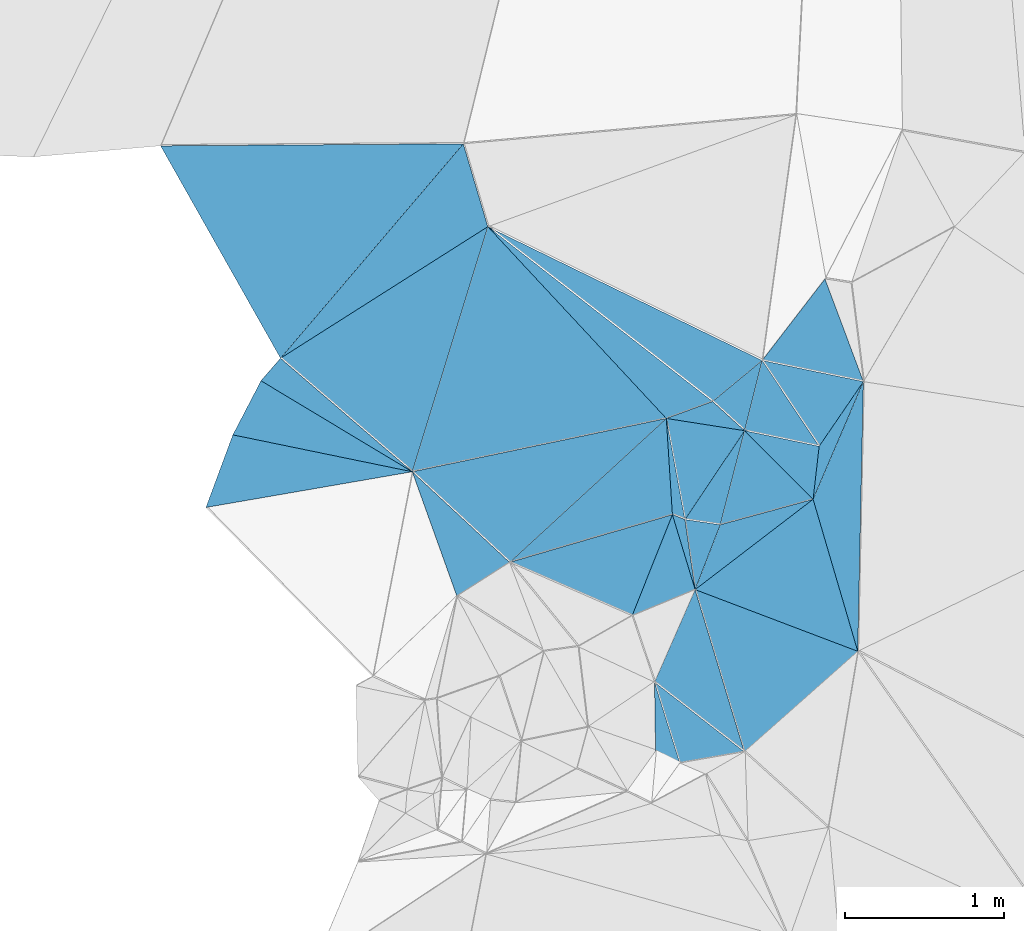
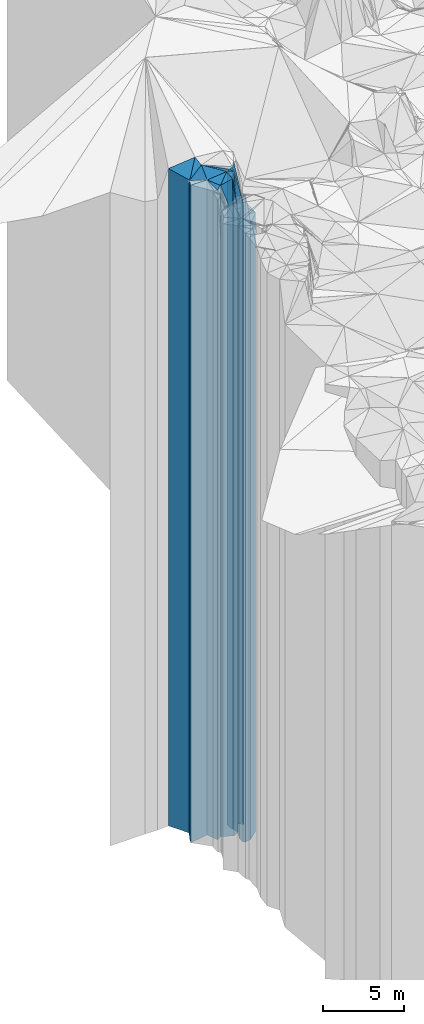
# One storey, part 238 of 275: 34 plates.
"""IFC2X3 building model written with IfcOpenShell, lengths in millimetres."""

from ifc_helpers import new_model, si_unit, frame, origin_with_axes, place, context, subcontext, project, spatial, faceted_brep, material, type_object, element, save


model = new_model("IFC2X3")

# Units and contexts
model_context = context("Model", 3, precision=1e-05, world=origin_with_axes())
body_context = subcontext(model_context, "Body", "Model", "MODEL_VIEW")
ifc_project = project(units=[si_unit("LENGTHUNIT", "METRE", prefix="MILLI"), si_unit("AREAUNIT", "SQUARE_METRE"), si_unit("VOLUMEUNIT", "CUBIC_METRE"), si_unit("MASSUNIT", "GRAM", prefix="KILO"), si_unit("TIMEUNIT", "SECOND"), si_unit("PLANEANGLEUNIT", "RADIAN"), si_unit("SOLIDANGLEUNIT", "STERADIAN"), si_unit("THERMODYNAMICTEMPERATUREUNIT", "DEGREE_CELSIUS"), si_unit("LUMINOUSINTENSITYUNIT", "LUMEN")], contexts=[model_context])

# Site, building, storey
site_placement = place(None, origin_with_axes())
site = spatial("IfcSite", under=ifc_project, at=site_placement, CompositionType="ELEMENT")
building_placement = place(site_placement, origin_with_axes())
building = spatial("IfcBuilding", under=site, at=building_placement, Name="Undefined", CompositionType="ELEMENT")
storey_placement = place(building_placement, origin_with_axes())
storey = spatial("IfcBuildingStorey", under=building, at=storey_placement, Name="Undefined", CompositionType="ELEMENT", Elevation=0.0)

# Plates
ifc_material = material()
plate_type_1 = type_object("IfcPlateType", PredefinedType="NOTDEFINED")
plate_1_placement = place(storey_placement, frame((-137889.922620238, 93996.6602586746, 32554.0), z_axis=(-0.201534010067387, -0.979481517327488, 0.0), x_axis=(-0.979481517327489, 0.201534010067382, 0.0)))
element("IfcPlate", 1, at=plate_1_placement, inside=storey, type_object=plate_type_1, material=ifc_material, Name="00", context=body_context, shape_type="Brep", body=[
    faceted_brep([(2.91038304567337e-11, -24726.0, 0.0), (1228.06140136722, -24926.0, 482.353698730476), (1228.06140136722, 24726.0, 482.353698730476), (2.91038304567337e-11, 24726.0, 0.0), (1154.33959960943, -24896.0, -1.62981450557709e-09), (1154.33959960943, 24726.0, -1.62981450557709e-09)], [[[0, 1, 2, 3]], [[1, 4, 5, 2]], [[4, 0, 3, 5]], [[5, 3, 2]], [[4, 1, 0]]]),
])
plate_type_2 = type_object("IfcPlateType", PredefinedType="NOTDEFINED")
plate_2_placement = place(storey_placement, frame((-135797.607146299, 92232.0594659979, 31079.0), z_axis=(-0.663004384163275, 0.748615513184356, 0.0), x_axis=(0.74861551318436, 0.663004384163271, 0.0)))
element("IfcPlate", 2, at=plate_2_placement, inside=storey, type_object=plate_type_2, material=ifc_material, Name="00", context=body_context, shape_type="Brep", body=[
    faceted_brep([(7.27595761418343e-12, -23251.0, 2.91038304567337e-11), (445.716400146506, -23401.0, 970.482788085908), (445.716400146506, 23251.0, 970.482788085908), (0.0, 23251.0, 2.91038304567337e-11), (955.09161376956, -23451.0, 1.17288436740637e-08), (955.09161376956, 23251.0, 1.17288436740637e-08)], [[[0, 1, 2, 3]], [[1, 4, 5, 2]], [[4, 0, 3, 5]], [[5, 3, 2]], [[4, 1, 0]]]),
])
plate_type_3 = type_object("IfcPlateType", PredefinedType="NOTDEFINED")
plate_3_placement = place(storey_placement, frame((-136107.371292026, 93254.0898833643, 31154.0), z_axis=(0.354732567030753, 0.93496781008106, 0.0), x_axis=(0.934967810081061, -0.354732567030751, 0.0)))
element("IfcPlate", 3, at=plate_3_placement, inside=storey, type_object=plate_type_3, material=ifc_material, Name="00", context=body_context, shape_type="Brep", body=[
    faceted_brep([(0.0, -23326.0, -7.27595761418343e-12), (493.048461914033, -23386.0, 795.866333007813), (493.048461914033, 23326.0, 795.866333007813), (0.0, 23326.0, -7.27595761418343e-12), (1096.03833007813, -23376.0, -1.30967237055302e-10), (1096.03833007813, 23326.0, -1.30967237055302e-10)], [[[0, 1, 2, 3]], [[1, 4, 5, 2]], [[4, 0, 3, 5]], [[5, 3, 2]], [[4, 1, 0]]]),
])
plate_type_4 = type_object("IfcPlateType", PredefinedType="NOTDEFINED")
plate_4_placement = place(storey_placement, frame((-135795.781477125, 94255.6445684663, 31199.0), z_axis=(0.830293936976665, -0.55732573798434, 0.0), x_axis=(-0.557325737984339, -0.830293936976666, 0.0)))
element("IfcPlate", 4, at=plate_4_placement, inside=storey, type_object=plate_type_4, material=ifc_material, Name="00", context=body_context, shape_type="Brep", body=[
    faceted_brep([(1.04591890703887e-11, -25831.0, 0.0), (577.602416992198, -23371.0, 202.917343139648), (577.602416992198, 23371.0, 202.917343139648), (1.04591890703887e-11, 23371.0, 0.0), (674.166137695323, -25701.0, 6.11180439591408e-09), (674.166137695323, 23371.0, 6.11180439591408e-09)], [[[0, 1, 2, 3]], [[1, 4, 5, 2]], [[4, 0, 3, 5]], [[5, 3, 2]], [[4, 1, 0]]]),
])
plate_type_5 = type_object("IfcPlateType", PredefinedType="NOTDEFINED")
plate_5_placement = place(storey_placement, frame((-136250.65043334, 93726.4997558948, 32364.0), z_axis=(0.360757109901238, 0.932659802744659, 0.0), x_axis=(0.932659802744688, -0.360757109901163, 0.0)))
element("IfcPlate", 5, at=plate_5_placement, inside=storey, type_object=plate_type_5, material=ifc_material, Name="00", context=body_context, shape_type="Brep", body=[
    faceted_brep([(1.45519152283669e-11, -24586.0, 1.45519152283669e-11), (-254.558441162109, -24796.0, 551.543273925796), (-254.558441162109, 24536.0, 551.543273925796), (0.0, 24536.0, 7.27595761418343e-12), (84.8528137207322, -24536.0, -6.54836185276508e-11), (84.8528137207322, 24536.0, -6.54836185276508e-11)], [[[0, 1, 2, 3]], [[1, 4, 5, 2]], [[4, 0, 3, 5]], [[5, 3, 2]], [[4, 1, 0]]]),
])
plate_type_6 = type_object("IfcPlateType", PredefinedType="NOTDEFINED")
plate_6_placement = place(storey_placement, frame((-136250.65043334, 93726.4997558948, 32389.0), z_axis=(-0.997995437407364, -0.0632859140258246, 0.0), x_axis=(-0.0632859140258196, 0.997995437407364, 0.0)))
element("IfcPlate", 6, at=plate_6_placement, inside=storey, type_object=plate_type_6, material=ifc_material, Name="00", context=body_context, shape_type="Brep", body=[
    faceted_brep([(0.0, -24561.0, 0.0), (-235.079650878892, -24621.0, 1043.04248046872), (-235.079650878892, 24561.0, 1043.04248046872), (0.0, 24561.0, 0.0), (607.453674316392, -24771.0, 1.42608769237995e-09), (607.453674316392, 24561.0, 1.42608769237995e-09)], [[[0, 1, 2, 3]], [[1, 4, 5, 2]], [[4, 0, 3, 5]], [[5, 3, 2]], [[4, 1, 0]]]),
])
plate_type_7 = type_object("IfcPlateType", PredefinedType="NOTDEFINED")
plate_7_placement = place(storey_placement, frame((-137609.148746292, 93213.2918704249, 32359.0), z_axis=(-0.538762878316238, 0.842457453494479, 0.0), x_axis=(0.842457453494479, 0.538762878316238, 0.0)))
element("IfcPlate", 7, at=plate_7_placement, inside=storey, type_object=plate_type_7, material=ifc_material, Name="00", context=body_context, shape_type="Brep", body=[
    faceted_brep([(0.0, -24531.0, -2.91038304567337e-11), (185.509765624978, -24921.0, 811.22509765625), (185.509765624978, 24531.0, 811.22509765625), (0.0, 24531.0, -2.91038304567337e-11), (394.588378906257, -24651.0, 3.57977114617825e-09), (394.588378906257, 24531.0, 3.57977114617825e-09)], [[[0, 1, 2, 3]], [[1, 4, 5, 2]], [[4, 0, 3, 5]], [[5, 3, 2]], [[4, 1, 0]]]),
])
plate_type_8 = type_object("IfcPlateType", PredefinedType="NOTDEFINED")
plate_8_placement = place(storey_placement, frame((-136289.093695986, 94332.7357788736, 32494.0), z_axis=(-0.731986727096025, -0.681318891089371, 0.0), x_axis=(-0.681318891089379, 0.731986727096017, 0.0)))
element("IfcPlate", 8, at=plate_8_placement, inside=storey, type_object=plate_type_8, material=ifc_material, Name="00", context=body_context, shape_type="Brep", body=[
    faceted_brep([(0.0, -24666.0, -7.27595761418343e-12), (844.672180175781, -24786.0, 1400.76013183593), (844.672180175781, 24666.0, 1400.76013183593), (0.0, 24666.0, -7.27595761418343e-12), (1650.81799316406, -24826.0, -5.54427970200777e-09), (1650.81799316406, 24666.0, -5.54427970200777e-09)], [[[0, 1, 2, 3]], [[1, 4, 5, 2]], [[4, 0, 3, 5]], [[5, 3, 2]], [[4, 1, 0]]]),
])
plate_type_9 = type_object("IfcPlateType", PredefinedType="NOTDEFINED")
plate_9_placement = place(storey_placement, frame((-137889.922620238, 93996.6602586746, 32469.0), z_axis=(-0.955625946903427, 0.294582839970235, 0.0), x_axis=(0.294582839970225, 0.95562594690343, 0.0)))
element("IfcPlate", 9, at=plate_9_placement, inside=storey, type_object=plate_type_9, material=ifc_material, Name="00", context=body_context, shape_type="Brep", body=[
    faceted_brep([(0.0, -24811.0, 0.0), (439.063171386711, -24641.0, 1004.10333251953), (439.063171386711, 24641.0, 1004.10333251953), (0.0, 24641.0, 0.0), (1616.16833496094, -24851.0, -1.11176632344723e-08), (1616.16833496094, 24641.0, -1.11176632344723e-08)], [[[0, 1, 2, 3]], [[1, 4, 5, 2]], [[4, 0, 3, 5]], [[5, 3, 2]], [[4, 1, 0]]]),
])
plate_type_10 = type_object("IfcPlateType", PredefinedType="NOTDEFINED")
plate_10_placement = place(storey_placement, frame((-138720.129348751, 94712.0320416884, 32469.0), z_axis=(-0.535861819967742, 0.844305696949191, 0.0), x_axis=(0.844305696949189, 0.535861819967746, 0.0)))
element("IfcPlate", 10, at=plate_10_placement, inside=storey, type_object=plate_type_10, material=ifc_material, Name="00", context=body_context, shape_type="Brep", body=[
    faceted_brep([(0.0, -24641.0, 0.0), (1696.68774414063, -25171.0, 523.594055175781), (1696.68774414063, 24641.0, 523.594055175781), (0.0, 24641.0, 0.0), (1547.19104003906, -24851.0, 3.31783667206764e-09), (1547.19104003906, 24641.0, 3.31783667206764e-09)], [[[0, 1, 2, 3]], [[1, 4, 5, 2]], [[4, 0, 3, 5]], [[5, 3, 2]], [[4, 1, 0]]]),
])
plate_type_11 = type_object("IfcPlateType", PredefinedType="NOTDEFINED")
plate_11_placement = place(storey_placement, frame((-136289.093695986, 94332.7357788736, 32484.0), z_axis=(-0.344674282034968, 0.938722344095249, 0.0), x_axis=(0.938722344095242, 0.344674282034987, 0.0)))
element("IfcPlate", 11, at=plate_11_placement, inside=storey, type_object=plate_type_11, material=ifc_material, Name="00", context=body_context, shape_type="Brep", body=[
    faceted_brep([(0.0, -24676.0, 0.0), (-639.316040039063, -24836.0, 1521.9970703125), (-639.316040039063, 24656.0, 1521.9970703125), (0.0, 24656.0, 0.0), (310.644500732422, -24656.0, 1.22236087918282e-09), (310.644500732422, 24656.0, 1.22236087918282e-09)], [[[0, 1, 2, 3]], [[1, 4, 5, 2]], [[4, 0, 3, 5]], [[5, 3, 2]], [[4, 1, 0]]]),
])
plate_type_12 = type_object("IfcPlateType", PredefinedType="NOTDEFINED")
plate_12_placement = place(storey_placement, frame((-137889.922620238, 93996.6602586746, 32419.0), z_axis=(0.681335722425563, 0.731971060457198, 0.0), x_axis=(0.731971060457192, -0.68133572242557, 0.0)))
element("IfcPlate", 12, at=plate_12_placement, inside=storey, type_object=plate_type_12, material=ifc_material, Name="00", context=body_context, shape_type="Brep", body=[
    faceted_brep([(0.0, -24861.0, 1.09139364212751e-11), (942.780212402373, -24741.0, 1336.69946289064), (942.780212402373, 24591.0, 1336.69946289064), (0.0, 24591.0, 1.09139364212751e-11), (837.735046386719, -24591.0, -4.00541466660798e-09), (837.735046386719, 24591.0, -4.00541466660798e-09)], [[[0, 1, 2, 3]], [[1, 4, 5, 2]], [[4, 0, 3, 5]], [[5, 3, 2]], [[4, 1, 0]]]),
])
plate_type_13 = type_object("IfcPlateType", PredefinedType="NOTDEFINED")
plate_13_placement = place(storey_placement, frame((-135685.280651673, 94698.1257178664, 32429.0), z_axis=(0.637484149966322, -0.770463469959294, 0.0), x_axis=(-0.770463469959307, -0.637484149966307, 0.0)))
element("IfcPlate", 13, at=plate_13_placement, inside=storey, type_object=plate_type_13, material=ifc_material, Name="00", context=body_context, shape_type="Brep", body=[
    faceted_brep([(-1.45519152283669e-11, -24651.0, -2.91038304567337e-11), (367.211578369119, -24601.0, 270.473022460908), (367.211578369119, 24601.0, 270.473022460908), (-1.45519152283669e-11, 24601.0, -2.91038304567337e-11), (405.216003417961, -24711.0, 1.65891833603382e-09), (405.216003417961, 24601.0, 1.65891833603382e-09)], [[[0, 1, 2, 3]], [[1, 4, 5, 2]], [[4, 0, 3, 5]], [[5, 3, 2]], [[4, 1, 0]]]),
])
plate_type_14 = type_object("IfcPlateType", PredefinedType="NOTDEFINED")
plate_14_placement = place(storey_placement, frame((-135949.213136859, 93662.9737274498, 31184.0), z_axis=(-0.264252388963586, 0.964453562867097, 0.0), x_axis=(0.9644535628671, 0.264252388963574, 0.0)))
element("IfcPlate", 14, at=plate_14_placement, inside=storey, type_object=plate_type_14, material=ifc_material, Name="00", context=body_context, shape_type="Brep", body=[
    faceted_brep([(-2.91038304567337e-11, -23386.0, 1.45519152283669e-11), (304.592407226563, -25846.0, 531.05883789064), (304.592407226563, 23356.0, 531.05883789064), (-2.91038304567337e-11, 23356.0, 1.45519152283669e-11), (606.712463378877, -23356.0, 2.95403879135847e-09), (606.712463378877, 23356.0, 2.95403879135847e-09)], [[[0, 1, 2, 3]], [[1, 4, 5, 2]], [[4, 0, 3, 5]], [[5, 3, 2]], [[4, 1, 0]]]),
])
plate_type_15 = type_object("IfcPlateType", PredefinedType="NOTDEFINED")
plate_15_placement = place(storey_placement, frame((-135325.862811632, 94157.2756311879, 31209.0), z_axis=(-0.825239496168493, 0.564782944115324, 0.0), x_axis=(0.5647829441153, 0.825239496168509, 0.0)))
element("IfcPlate", 15, at=plate_15_placement, inside=storey, type_object=plate_type_15, material=ifc_material, Name="00", context=body_context, shape_type="Brep", body=[
    faceted_brep([(-6.3664629124105e-12, -23381.0, 2.91038304567337e-11), (243.33778381347, -25871.0, 602.068725585967), (243.33778381347, 23381.0, 602.068725585967), (-6.3664629124105e-12, 23381.0, 2.91038304567337e-11), (493.963562011712, -23391.0, -1.45519152283669e-09), (493.963562011712, 23381.0, -1.45519152283669e-09)], [[[0, 1, 2, 3]], [[1, 4, 5, 2]], [[4, 0, 3, 5]], [[5, 3, 2]], [[4, 1, 0]]]),
])
plate_type_16 = type_object("IfcPlateType", PredefinedType="NOTDEFINED")
plate_16_placement = place(storey_placement, frame((-135795.781477125, 94255.6445684663, 31184.0), z_axis=(0.70762321845834, 0.706589966457677, 0.0), x_axis=(0.706589966457669, -0.707623218458348, 0.0)))
element("IfcPlate", 16, at=plate_16_placement, inside=storey, type_object=plate_type_16, material=ifc_material, Name="00", context=body_context, shape_type="Brep", body=[
    faceted_brep([(-2.91038304567337e-11, -25846.0, 2.18278728425503e-11), (401.647949218721, -23406.0, 263.018859863303), (401.647949218721, 23356.0, 263.018859863303), (-2.91038304567337e-11, 23356.0, 1.45519152283669e-11), (610.982788085908, -23356.0, 5.98811311647296e-09), (610.982788085908, 23356.0, 5.98811311647296e-09)], [[[0, 1, 2, 3]], [[1, 4, 5, 2]], [[4, 0, 3, 5]], [[5, 3, 2]], [[4, 1, 0]]]),
])
plate_type_17 = type_object("IfcPlateType", PredefinedType="NOTDEFINED")
plate_17_placement = place(storey_placement, frame((-135325.862811632, 94157.2756311879, 31184.0), z_axis=(0.993520728489329, -0.113651053941584, 0.0), x_axis=(-0.113651053941594, -0.993520728489328, 0.0)))
element("IfcPlate", 17, at=plate_17_placement, inside=storey, type_object=plate_type_17, material=ifc_material, Name="00", context=body_context, shape_type="Brep", body=[
    faceted_brep([(-1.45519152283669e-11, -23406.0, 0.0), (-436.703674316421, -23416.0, 230.846084594727), (-436.703674316421, 23356.0, 230.846084594727), (-2.91038304567337e-11, 23356.0, 1.45519152283669e-11), (336.154724121079, -23356.0, -3.78349795937538e-10), (336.154724121079, 23356.0, -3.78349795937538e-10)], [[[0, 1, 2, 3]], [[1, 4, 5, 2]], [[4, 0, 3, 5]], [[5, 3, 2]], [[4, 1, 0]]]),
])
plate_type_18 = type_object("IfcPlateType", PredefinedType="NOTDEFINED")
plate_18_placement = place(storey_placement, frame((-135289.330690367, 95212.1525927886, 31214.0), z_axis=(0.792218131532693, -0.610238012640026, 0.0), x_axis=(-0.610238012640019, -0.792218131532699, 0.0)))
element("IfcPlate", 18, at=plate_18_placement, inside=storey, type_object=plate_type_18, material=ifc_material, Name="00", context=body_context, shape_type="Brep", body=[
    faceted_brep([(0.0, -25806.0, 1.45519152283669e-11), (364.80200195311, -23386.0, 587.043029785156), (364.80200195311, 23386.0, 587.043029785156), (3.63797880709171e-12, 23386.0, 0.0), (648.845153808594, -25866.0, 3.20142135024071e-10), (648.845153808594, 23386.0, 3.20142135024071e-10)], [[[0, 1, 2, 3]], [[1, 4, 5, 2]], [[4, 0, 3, 5]], [[5, 3, 2]], [[4, 1, 0]]]),
])
plate_type_19 = type_object("IfcPlateType", PredefinedType="NOTDEFINED")
plate_19_placement = place(storey_placement, frame((-137413.827170678, 95541.1126285805, 32454.0), z_axis=(0.613838519303279, 0.789431613390012, 0.0), x_axis=(0.789431613390022, -0.613838519303267, 0.0)))
element("IfcPlate", 19, at=plate_19_placement, inside=storey, type_object=plate_type_19, material=ifc_material, Name="00", context=body_context, shape_type="Brep", body=[
    faceted_brep([(0.0, -24866.0, 1.81898940354586e-12), (1882.02709960938, -24626.0, 395.567932128923), (1882.02709960938, 24626.0, 395.567932128923), (0.0, 24626.0, 1.81898940354586e-12), (1794.12927246094, -24686.0, 2.45508999796584e-08), (1794.12927246094, 24626.0, 2.45508999796584e-08)], [[[0, 1, 2, 3]], [[1, 4, 5, 2]], [[4, 0, 3, 5]], [[5, 3, 2]], [[4, 1, 0]]]),
])
plate_type_20 = type_object("IfcPlateType", PredefinedType="NOTDEFINED")
plate_20_placement = place(storey_placement, frame((-135795.781477125, 94255.6445684663, 32429.0), z_axis=(-0.67426636979517, -0.738488227775665, 0.0), x_axis=(-0.73848822777566, 0.674266369795176, 0.0)))
element("IfcPlate", 20, at=plate_20_placement, inside=storey, type_object=plate_type_20, material=ifc_material, Name="00", context=body_context, shape_type="Brep", body=[
    faceted_brep([(0.0, -24601.0, 0.0), (416.285278320313, -24731.0, 275.692901611314), (416.285278320313, 24601.0, 275.692901611314), (-1.45519152283669e-11, 24601.0, -2.91038304567337e-11), (273.130004882813, -24711.0, 8.14907252788544e-10), (273.130004882813, 24601.0, 8.14907252788544e-10)], [[[0, 1, 2, 3]], [[1, 4, 5, 2]], [[4, 0, 3, 5]], [[5, 3, 2]], [[4, 1, 0]]]),
])
plate_type_21 = type_object("IfcPlateType", PredefinedType="NOTDEFINED")
plate_21_placement = place(storey_placement, frame((-135795.781477125, 94255.6445684663, 31209.0), z_axis=(0.204890826969305, 0.978784832853388, 0.0), x_axis=(0.978784832853385, -0.204890826969316, 0.0)))
element("IfcPlate", 21, at=plate_21_placement, inside=storey, type_object=plate_type_21, material=ifc_material, Name="00", context=body_context, shape_type="Brep", body=[
    faceted_brep([(0.0, -25821.0, -7.27595761418343e-12), (17.4962043762207, -25871.0, 455.734436035156), (17.4962043762207, 23381.0, 455.734436035156), (-6.3664629124105e-12, 23381.0, 2.91038304567337e-11), (480.104156494141, -23381.0, -1.3169483281672e-09), (480.104156494141, 23381.0, -1.3169483281672e-09)], [[[0, 1, 2, 3]], [[1, 4, 5, 2]], [[4, 0, 3, 5]], [[5, 3, 2]], [[4, 1, 0]]]),
])
plate_type_22 = type_object("IfcPlateType", PredefinedType="NOTDEFINED")
plate_22_placement = place(storey_placement, frame((-138720.129348751, 94712.0320416884, 32469.0), z_axis=(-0.761000575060208, 0.648751204051316, 0.0), x_axis=(0.648751204051319, 0.761000575060206, 0.0)))
element("IfcPlate", 22, at=plate_22_placement, inside=storey, type_object=plate_type_22, material=ifc_material, Name="00", context=body_context, shape_type="Brep", body=[
    faceted_brep([(0.0, -24641.0, 0.0), (528.316345214873, -24991.0, 1443.70422363281), (528.316345214873, 24641.0, 1443.70422363281), (0.0, 24641.0, 0.0), (1775.64074707033, -25171.0, 1.21071934700012e-08), (1775.64074707033, 24641.0, 1.21071934700012e-08)], [[[0, 1, 2, 3]], [[1, 4, 5, 2]], [[4, 0, 3, 5]], [[5, 3, 2]], [[4, 1, 0]]]),
])
plate_type_23 = type_object("IfcPlateType", PredefinedType="NOTDEFINED")
plate_23_placement = place(storey_placement, frame((-136289.093695986, 94332.7357788736, 32364.0), z_axis=(0.983379350187633, 0.181562809034638, 0.0), x_axis=(0.18156280903462, -0.983379350187636, 0.0)))
element("IfcPlate", 23, at=plate_23_placement, inside=storey, type_object=plate_type_23, material=ifc_material, Name="00", context=body_context, shape_type="Brep", body=[
    faceted_brep([(0.0, -24796.0, -2.91038304567337e-11), (165.377059936509, -24666.0, 471.116149902329), (165.377059936509, 24536.0, 471.116149902329), (0.0, 24536.0, 7.27595761418343e-12), (647.611022949204, -24536.0, 1.14960130304098e-09), (647.611022949204, 24536.0, 1.14960130304098e-09)], [[[0, 1, 2, 3]], [[1, 4, 5, 2]], [[4, 0, 3, 5]], [[5, 3, 2]], [[4, 1, 0]]]),
])
plate_type_24 = type_object("IfcPlateType", PredefinedType="NOTDEFINED")
plate_24_placement = place(storey_placement, frame((-136107.371292026, 93254.0898833643, 31154.0), z_axis=(-0.989625101192178, -0.143673794027901, 0.0), x_axis=(-0.143673794027893, 0.989625101192179, 0.0)))
element("IfcPlate", 24, at=plate_24_placement, inside=storey, type_object=plate_type_24, material=ifc_material, Name="00", context=body_context, shape_type="Brep", body=[
    faceted_brep([(0.0, -23326.0, -7.27595761418343e-12), (488.094116210952, -25796.0, 73.9197158813477), (488.094116210952, 23326.0, 73.9197158813477), (0.0, 23326.0, -7.27595761418343e-12), (446.430297851577, -25746.0, 2.8085196390748e-09), (446.430297851577, 23326.0, 2.8085196390748e-09)], [[[0, 1, 2, 3]], [[1, 4, 5, 2]], [[4, 0, 3, 5]], [[5, 3, 2]], [[4, 1, 0]]]),
])
plate_type_25 = type_object("IfcPlateType", PredefinedType="NOTDEFINED")
plate_25_placement = place(storey_placement, frame((-135364.067150481, 93823.2989426405, 31154.0), z_axis=(0.264252388963593, -0.964453562867095, 0.0), x_axis=(-0.964453562867097, -0.264252388963587, 0.0)))
element("IfcPlate", 25, at=plate_25_placement, inside=storey, type_object=plate_type_25, material=ifc_material, Name="00", context=body_context, shape_type="Brep", body=[
    faceted_brep([(-2.91038304567337e-11, -23386.0, 1.45519152283669e-11), (867.297180175781, -23326.0, 352.555816650376), (867.297180175781, 23326.0, 352.555816650376), (0.0, 23326.0, -7.27595761418343e-12), (606.712463378906, -23416.0, 2.9831426218152e-09), (606.712463378906, 23326.0, 2.9831426218152e-09)], [[[0, 1, 2, 3]], [[1, 4, 5, 2]], [[4, 0, 3, 5]], [[5, 3, 2]], [[4, 1, 0]]]),
])
plate_type_26 = type_object("IfcPlateType", PredefinedType="NOTDEFINED")
plate_26_placement = place(storey_placement, frame((-136250.65043334, 93726.4997558948, 31154.0), z_axis=(0.928891296840331, -0.370352478936335, 0.0), x_axis=(-0.370352478936329, -0.928891296840333, 0.0)))
element("IfcPlate", 26, at=plate_26_placement, inside=storey, type_object=plate_type_26, material=ifc_material, Name="00", context=body_context, shape_type="Brep", body=[
    faceted_brep([(0.0, -25796.0, 0.0), (385.75363159179, -23326.0, 308.048919677734), (385.75363159179, 23326.0, 308.048919677734), (0.0, 23326.0, -7.27595761418343e-12), (685.93005371093, -23346.0, -5.96628524363041e-09), (685.93005371093, 23326.0, -5.96628524363041e-09)], [[[0, 1, 2, 3]], [[1, 4, 5, 2]], [[4, 0, 3, 5]], [[5, 3, 2]], [[4, 1, 0]]]),
])
plate_type_27 = type_object("IfcPlateType", PredefinedType="NOTDEFINED")
plate_27_placement = place(storey_placement, frame((-135046.880617168, 94564.9138717546, 31179.0), z_axis=(0.919435851972853, -0.393240020988396, 0.0), x_axis=(-0.393240020988381, -0.919435851972859, 0.0)))
element("IfcPlate", 27, at=plate_27_placement, inside=storey, type_object=plate_type_27, material=ifc_material, Name="00", context=body_context, shape_type="Brep", body=[
    faceted_brep([(7.27595761418343e-12, -23421.0, 0.0), (1576.74621582029, -23351.0, 635.5087890625), (1576.74621582029, 23351.0, 635.5087890625), (0.0, 23351.0, -1.45519152283669e-11), (806.59777832032, -23361.0, -5.20958565175533e-09), (806.59777832032, 23351.0, -5.20958565175533e-09)], [[[0, 1, 2, 3]], [[1, 4, 5, 2]], [[4, 0, 3, 5]], [[5, 3, 2]], [[4, 1, 0]]]),
])
plate_type_28 = type_object("IfcPlateType", PredefinedType="NOTDEFINED")
plate_28_placement = place(storey_placement, frame((-137889.922620238, 93996.6602586746, 32454.0), z_axis=(-0.652770173172976, -0.757556005200753, 0.0), x_axis=(-0.757556005200756, 0.652770173172972, 0.0)))
element("IfcPlate", 28, at=plate_28_placement, inside=storey, type_object=plate_type_28, material=ifc_material, Name="00", context=body_context, shape_type="Brep", body=[
    faceted_brep([(-2.91038304567337e-11, -24826.0, 1.81898940354586e-11), (1096.54016113281, -24626.0, 187.881851196307), (1096.54016113281, 24626.0, 187.881851196307), (0.0, 24626.0, 1.81898940354586e-12), (1095.90148925781, -24656.0, -3.51792550645769e-09), (1095.90148925781, 24626.0, -3.51792550645769e-09)], [[[0, 1, 2, 3]], [[1, 4, 5, 2]], [[4, 0, 3, 5]], [[5, 3, 2]], [[4, 1, 0]]]),
])
plate_type_29 = type_object("IfcPlateType", PredefinedType="NOTDEFINED")
plate_29_placement = place(storey_placement, frame((-137889.922620238, 93996.6602586746, 32454.0), z_axis=(-0.515458491674549, -0.856914548458946, 0.0), x_axis=(-0.856914548458945, 0.51545849167455, 0.0)))
element("IfcPlate", 29, at=plate_29_placement, inside=storey, type_object=plate_type_29, material=ifc_material, Name="00", context=body_context, shape_type="Brep", body=[
    faceted_brep([(-2.91038304567337e-11, -24826.0, 1.81898940354586e-11), (1088.7897949219, -24996.0, 383.453887939459), (1088.7897949219, 24626.0, 383.453887939459), (0.0, 24626.0, 1.81898940354586e-12), (1112.51965332034, -24626.0, -1.25965016195551e-08), (1112.51965332034, 24626.0, -1.25965016195551e-08)], [[[0, 1, 2, 3]], [[1, 4, 5, 2]], [[4, 0, 3, 5]], [[5, 3, 2]], [[4, 1, 0]]]),
])
plate_type_30 = type_object("IfcPlateType", PredefinedType="NOTDEFINED")
plate_30_placement = place(storey_placement, frame((-136250.65043334, 93726.4997558948, 31164.0), z_axis=(0.281160505918548, -0.959660757722033, 0.0), x_axis=(-0.959660757722031, -0.281160505918556, 0.0)))
element("IfcPlate", 30, at=plate_30_placement, inside=storey, type_object=plate_type_30, material=ifc_material, Name="00", context=body_context, shape_type="Brep", body=[
    faceted_brep([(0.0, -25786.0, 0.0), (422.930938720703, -23336.0, 540.027221679688), (422.930938720703, 23336.0, 540.027221679688), (0.0, 23336.0, 0.0), (1069.20532226563, -25846.0, -6.40284270048141e-10), (1069.20532226563, 23336.0, -6.40284270048141e-10)], [[[0, 1, 2, 3]], [[1, 4, 5, 2]], [[4, 0, 3, 5]], [[5, 3, 2]], [[4, 1, 0]]]),
])
plate_type_31 = type_object("IfcPlateType", PredefinedType="NOTDEFINED")
plate_31_placement = place(storey_placement, frame((-136107.371292026, 93254.0898833643, 31079.0), z_axis=(0.915722182731736, -0.401812000882284, 0.0), x_axis=(-0.401812000882276, -0.91572218273174, 0.0)))
element("IfcPlate", 31, at=plate_31_placement, inside=storey, type_object=plate_type_31, material=ifc_material, Name="00", context=body_context, shape_type="Brep", body=[
    faceted_brep([(0.0, -23401.0, 0.0), (811.428955078103, -23251.0, 694.32196044919), (811.428955078103, 23251.0, 694.32196044919), (0.0, 23251.0, 2.91038304567337e-11), (637.024353027329, -23271.0, 3.49245965480804e-10), (637.024353027329, 23251.0, 3.49245965480804e-10)], [[[0, 1, 2, 3]], [[1, 4, 5, 2]], [[4, 0, 3, 5]], [[5, 3, 2]], [[4, 1, 0]]]),
])
plate_type_32 = type_object("IfcPlateType", PredefinedType="NOTDEFINED")
plate_32_placement = place(storey_placement, frame((-135797.607146299, 92232.0594659979, 31079.0), z_axis=(-0.612793110612607, -0.790243382500433, 0.0), x_axis=(-0.790243382500441, 0.612793110612596, 0.0)))
element("IfcPlate", 32, at=plate_32_placement, inside=storey, type_object=plate_type_32, material=ifc_material, Name="00", context=body_context, shape_type="Brep", body=[
    faceted_brep([(7.27595761418343e-12, -23251.0, 2.91038304567337e-11), (277.975250244112, -25651.0, 304.515594482431), (277.975250244112, 23251.0, 304.515594482431), (0.0, 23251.0, 2.91038304567337e-11), (715.891052246094, -23271.0, 4.01087163481861e-09), (715.891052246094, 23251.0, 4.01087163481861e-09)], [[[0, 1, 2, 3]], [[1, 4, 5, 2]], [[4, 0, 3, 5]], [[5, 3, 2]], [[4, 1, 0]]]),
])
plate_type_33 = type_object("IfcPlateType", PredefinedType="NOTDEFINED")
plate_33_placement = place(storey_placement, frame((-136357.056062541, 92236.1716570943, 31089.0), z_axis=(0.436964148096435, 0.899478923198513, 0.0), x_axis=(0.899478923198496, -0.43696414809647, 0.0)))
element("IfcPlate", 33, at=plate_33_placement, inside=storey, type_object=plate_type_33, material=ifc_material, Name="00", context=body_context, shape_type="Brep", body=[
    faceted_brep([(0.0, -25641.0, 1.09139364212751e-11), (-195.544326782197, -23261.0, 388.152557373072), (-195.544326782197, 23261.0, 388.152557373072), (0.0, 23261.0, 0.0), (170.293869018555, -25641.0, 1.32058630697429e-09), (170.293869018555, 23261.0, 1.32058630697429e-09)], [[[0, 1, 2, 3]], [[1, 4, 5, 2]], [[4, 0, 3, 5]], [[5, 3, 2]], [[4, 1, 0]]]),
])
plate_type_34 = type_object("IfcPlateType", PredefinedType="NOTDEFINED")
plate_34_placement = place(storey_placement, frame((-136107.371292026, 93254.0898833643, 31154.0), z_axis=(-0.932659802744667, 0.360757109901216, 0.0), x_axis=(0.360757109901238, 0.932659802744659, 0.0)))
element("IfcPlate", 34, at=plate_34_placement, inside=storey, type_object=plate_type_34, material=ifc_material, Name="00", context=body_context, shape_type="Brep", body=[
    faceted_brep([(0.0, -23326.0, -7.27595761418343e-12), (388.908721923814, -25746.0, 219.20310974124), (388.908721923814, 23326.0, 219.20310974124), (0.0, 23326.0, -7.27595761418343e-12), (438.406219482429, -23416.0, -5.23868948221207e-10), (438.406219482429, 23326.0, -5.23868948221207e-10)], [[[0, 1, 2, 3]], [[1, 4, 5, 2]], [[4, 0, 3, 5]], [[5, 3, 2]], [[4, 1, 0]]]),
])

save(model, "model.ifc")
